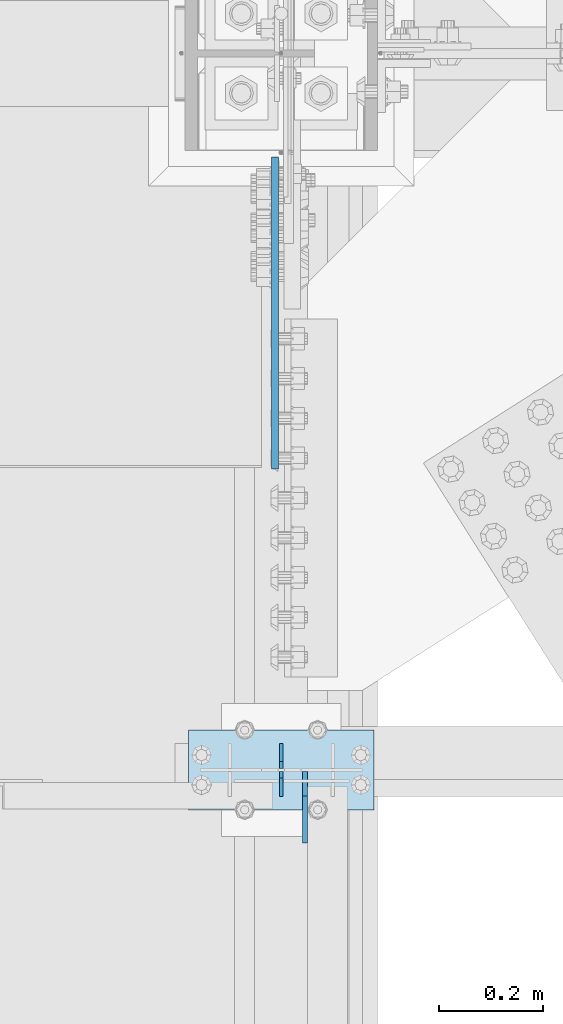
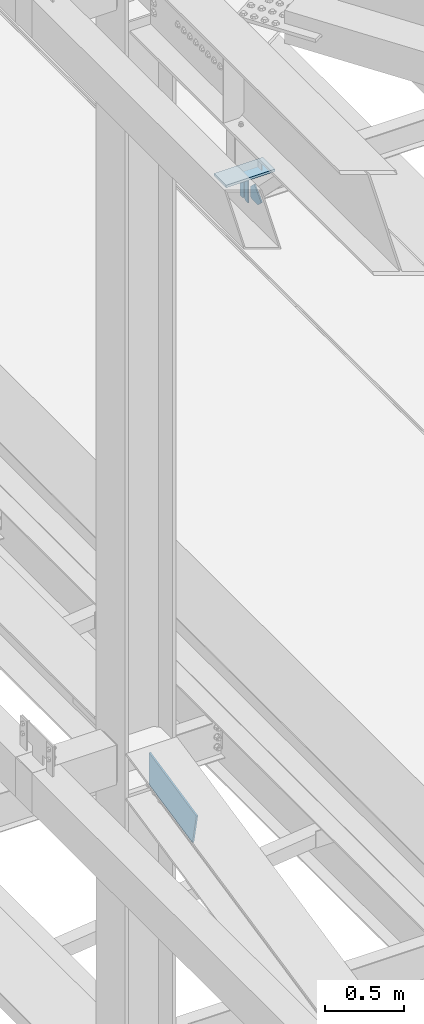
# One storey, part 3228 of 3843: 5 plates, 3 elements without a shape of their own.
"""IFC2X3 building model written with IfcOpenShell, lengths in millimetres."""

from ifc_helpers import new_model, si_unit, frame, origin_with_axes, place, context, subcontext, project, spatial, faceted_brep, material, type_object, element, aggregate, save


model = new_model("IFC2X3")

# Units and contexts
model_context = context("Model", 3, precision=1e-05, world=origin_with_axes())
body_context = subcontext(model_context, "Body", "Model", "MODEL_VIEW")
ifc_project = project(units=[si_unit("LENGTHUNIT", "METRE", prefix="MILLI"), si_unit("AREAUNIT", "SQUARE_METRE"), si_unit("VOLUMEUNIT", "CUBIC_METRE"), si_unit("MASSUNIT", "GRAM", prefix="KILO"), si_unit("TIMEUNIT", "SECOND"), si_unit("PLANEANGLEUNIT", "RADIAN"), si_unit("SOLIDANGLEUNIT", "STERADIAN"), si_unit("THERMODYNAMICTEMPERATUREUNIT", "DEGREE_CELSIUS"), si_unit("LUMINOUSINTENSITYUNIT", "LUMEN")], contexts=[model_context])

# Site, building, storey
site_placement = place(None, origin_with_axes())
site = spatial("IfcSite", under=ifc_project, at=site_placement, CompositionType="ELEMENT")
building_placement = place(site_placement, origin_with_axes())
building = spatial("IfcBuilding", under=site, at=building_placement, Name="Undefined", CompositionType="ELEMENT")
storey_placement = place(building_placement, origin_with_axes())
storey = spatial("IfcBuildingStorey", under=building, at=storey_placement, Name="Undefined", CompositionType="ELEMENT", Elevation=0.0)

# Assembly, plates
assembly_1_placement = place(storey_placement, origin_with_axes())
assembly_1 = element("IfcElementAssembly", 1, at=assembly_1_placement, inside=storey, Name="BEAM", AssemblyPlace="NOTDEFINED", PredefinedType="RIGID_FRAME")
ifc_material = material(Name="STEEL/A572-50")
plate_type_1 = type_object("IfcPlateType", PredefinedType="NOTDEFINED")
plate_1_placement = place(assembly_1_placement, frame((36576.0000030517, 40881.3, 41495.6625), z_axis=(0.0, 0.0, -1.0), x_axis=(0.0, -1.0, 0.0)))
plate_1 = element("IfcPlate", 2, at=plate_1_placement, type_object=plate_type_1, material=ifc_material, Name="PLATE", context=body_context, shape_type="Brep", body=[
    faceted_brep([(0.0, -3.17499999999927, 0.0), (0.0, -3.17500000000291, 187.324999999997), (0.0, 3.17500000000291, 187.324999999997), (0.0, 3.17499999999927, 0.0), (34.9250001907349, -3.17500000000291, 187.324999999997), (34.9250001907349, 3.17500000000291, 187.324999999997), (47.625, -3.17500000000291, 174.625000190732), (47.625, 3.17500000000291, 174.625000190732), (47.625, -3.17499999999927, 12.6999998092651), (47.625, 3.17499999999927, 12.6999998092651), (34.9250001907349, -3.17499999999927, 0.0), (34.9250001907349, 3.17499999999927, 0.0)], [[[0, 1, 2, 3]], [[1, 4, 5, 2]], [[4, 6, 7, 5]], [[6, 8, 9, 7]], [[8, 10, 11, 9]], [[10, 0, 3, 11]], [[5, 7, 9, 11, 3, 2]], [[10, 8, 6, 4, 1, 0]]]),
])
plate_2_placement = place(assembly_1_placement, frame((36576.0000030517, 40779.7, 41495.6625), z_axis=(0.0, 0.0, -1.0), x_axis=(0.0, 1.0, 0.0)))
plate_2 = element("IfcPlate", 3, at=plate_2_placement, type_object=plate_type_1, material=ifc_material, Name="PLATE", context=body_context, shape_type="Brep", body=[
    faceted_brep([(0.0, -3.17499999999927, 0.0), (0.0, -3.17500000000291, 187.324999999997), (0.0, 3.17500000000291, 187.324999999997), (0.0, 3.17499999999927, 0.0), (34.9250001907349, -3.17500000000291, 187.324999999997), (34.9250001907349, 3.17500000000291, 187.324999999997), (47.625, -3.17500000000291, 174.625000190732), (47.625, 3.17500000000291, 174.625000190732), (47.625, -3.17499999999927, 12.6999998092651), (47.625, 3.17499999999927, 12.6999998092651), (34.9250001907349, -3.17499999999927, 0.0), (34.9250001907349, 3.17499999999927, 0.0)], [[[0, 1, 2, 3]], [[1, 4, 5, 2]], [[4, 6, 7, 5]], [[6, 8, 9, 7]], [[8, 10, 11, 9]], [[10, 0, 3, 11]], [[5, 7, 9, 11, 3, 2]], [[10, 8, 6, 4, 1, 0]]]),
])

# Assembly, plate
assembly_2_placement = place(storey_placement, origin_with_axes())
assembly_2 = element("IfcElementAssembly", 4, at=assembly_2_placement, inside=storey, Name="POST", AssemblyPlace="NOTDEFINED", PredefinedType="RIGID_FRAME")
plate_type_2 = type_object("IfcPlateType", PredefinedType="NOTDEFINED")
plate_3_placement = place(assembly_2_placement, frame((36753.8000030518, 40754.3, 41513.125), z_axis=(-1.0, 0.0, 0.0), x_axis=(0.0, 1.0, 0.0)))
plate_3 = element("IfcPlate", 5, at=plate_3_placement, type_object=plate_type_2, material=ifc_material, Name="PLATE", context=body_context, shape_type="Brep", body=[
    faceted_brep([(0.0, -9.52500000000146, 0.0), (0.0, -9.52500000000146, 355.599999999999), (0.0, 9.52500000000146, 355.599999999999), (0.0, 9.52500000000146, 0.0), (152.399999999994, -9.52500000000146, 355.599999999999), (152.399999999994, 9.52500000000146, 355.599999999999), (152.400000000001, -9.52500000000146, 0.0), (152.400000000001, 9.52500000000146, 0.0)], [[[0, 1, 2, 3]], [[1, 4, 5, 2]], [[4, 6, 7, 5]], [[6, 0, 3, 7]], [[5, 7, 3, 2]], [[6, 4, 1, 0]]]),
])
aggregate(assembly_2, [plate_3])

# Plate
plate_type_3 = type_object("IfcPlateType", PredefinedType="NOTDEFINED")
plate_4_placement = place(assembly_1_placement, frame((36622.0375, 40827.325, 41306.75), z_axis=(0.0, -1.0, 0.0), x_axis=(0.0, 0.0, 1.0)))
plate_4 = element("IfcPlate", 6, at=plate_4_placement, type_object=plate_type_3, material=ifc_material, Name="PLATE", context=body_context, shape_type="Brep", body=[
    faceted_brep([(0.0, -4.76250000000073, 12.6999998092651), (4.450703272596e-08, -4.76249999999709, 93.0710244828806), (4.450703272596e-08, 4.76249999999709, 93.0710244828806), (0.0, 4.76250000000073, 12.6999998092651), (43.3137807601452, -4.76249999999709, 136.384805065652), (43.3137807601452, 4.76249999999709, 136.384805065652), (133.209805202001, -4.76249999999709, 46.4887805392646), (133.209805202001, 4.76249999999709, 46.4887805392646), (86.7210245267561, -4.76249999999709, 0.0), (86.7210245267561, 4.76249999999709, 0.0), (12.6999998092651, -4.76250000000073, 0.0), (12.6999998092651, 4.76250000000073, 0.0)], [[[0, 1, 2, 3]], [[1, 4, 5, 2]], [[4, 6, 7, 5]], [[6, 8, 9, 7]], [[8, 10, 11, 9]], [[10, 0, 3, 11]], [[5, 7, 9, 11, 3, 2]], [[10, 8, 6, 4, 1, 0]]]),
])

aggregate(assembly_1, [plate_1, plate_2, plate_4])

# Assembly, plate
assembly_3_placement = place(storey_placement, origin_with_axes())
assembly_3 = element("IfcElementAssembly", 7, at=assembly_3_placement, inside=storey, Name="BEAM", AssemblyPlace="NOTDEFINED", PredefinedType="RIGID_FRAME")
plate_type_4 = type_object("IfcPlateType", PredefinedType="NOTDEFINED")
plate_5_placement = place(assembly_3_placement, frame((36564.09375, 42003.6625001362, 36342.1421295768), z_axis=(0.0, -1.0, 0.0), x_axis=(0.0, 0.0, -1.0)))
plate_5 = element("IfcPlate", 8, at=plate_5_placement, type_object=plate_type_4, material=ifc_material, Name="PLATE", context=body_context, shape_type="Brep", body=[
    faceted_brep([(0.0, -6.3499999046162, 0.0), (126.974884468778, -6.34999999999854, 596.78196784087), (126.974884468778, 6.34999999999854, 596.78196784087), (7.27595761418343e-12, 6.3499999046162, 0.0), (362.991821724638, -6.34999999999854, 546.565598211964), (362.991821724638, 6.34999999999854, 546.565598211964), (246.701293945312, -6.34999999999854, 0.0), (246.701293945312, 6.34999999999854, 0.0)], [[[0, 1, 2, 3]], [[1, 4, 5, 2]], [[4, 6, 7, 5]], [[6, 0, 3, 7]], [[5, 7, 3, 2]], [[6, 4, 1, 0]]]),
])
aggregate(assembly_3, [plate_5])

save(model, "model.ifc")
